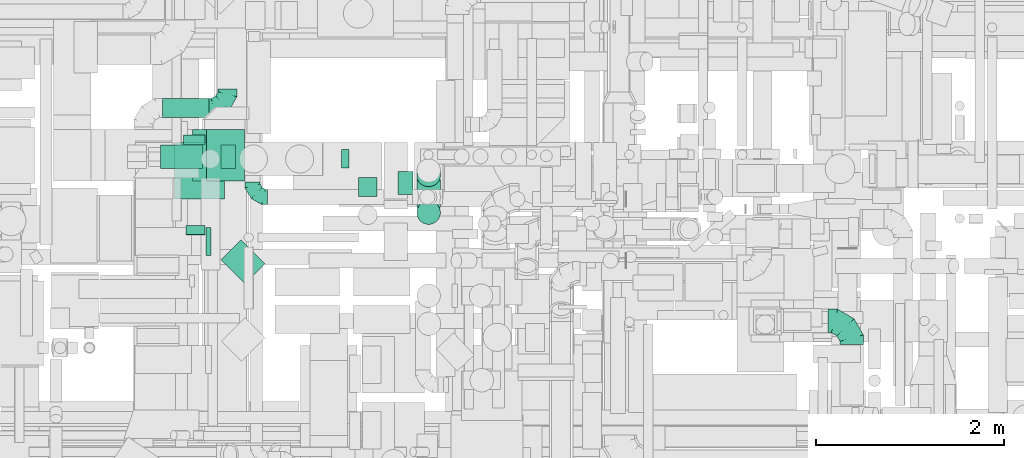
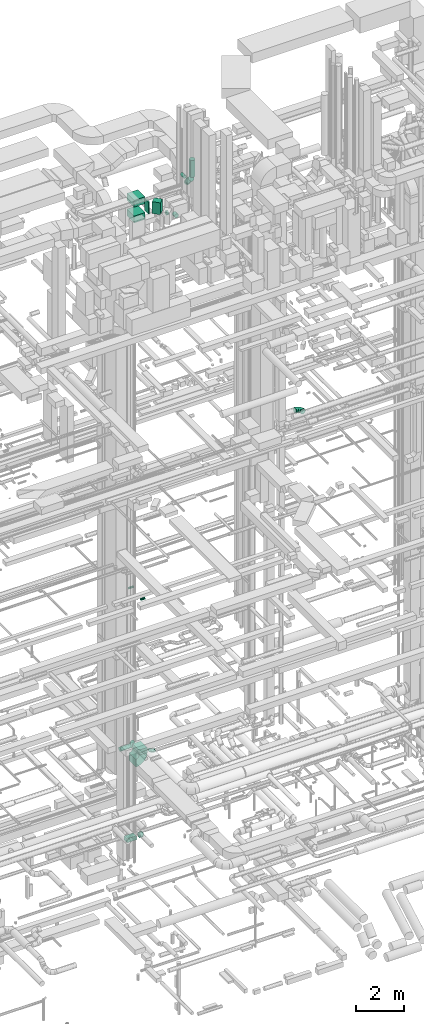
# One storey, part 188 of 337: 16 flow segments, 5 flow fittings.
"""IFC2X3 building model written with IfcOpenShell, lengths in millimetres."""

import ifcopenshell
import ifcopenshell.guid

model = None  # the IFC model being written
_history = None  # IfcOwnerHistory: only IFC2X3 demands one
_inside = {}  # id of a spatial element -> (the spatial element, [elements in it])
_under = {}  # id of a project, library or spatial element -> (it, [spatial elements below it])
_declared = {}  # id of a project -> (the project, [libraries it declares])
_typed = {}  # id of a type object -> (the type object, [elements of that type])
_made_of = {}  # id of a material, layer set ... -> (it, [elements and type objects made of it])


def new_model(schema):
    """Start an empty IFC model of exactly this schema.

    Asked for "IFC4X3", IfcOpenShell would pick the latest addendum, in which some entities
    have other attributes; the version numbers below select the first issue.
    IFC2X3 requires an IfcOwnerHistory on every rooted entity: one is made here for all.
    """
    global model, _history
    if schema == "IFC4X3":
        model = ifcopenshell.file(schema_version=(4, 3, 0, 0))
    else:
        model = ifcopenshell.file(schema=schema)
    _inside.clear()
    _under.clear()
    _declared.clear()
    _typed.clear()
    _made_of.clear()
    _history = None
    if model.schema == "IFC2X3":
        org = make("IfcOrganization", Name="unknown")
        user = make(
            "IfcPersonAndOrganization",
            ThePerson=make("IfcPerson", FamilyName="unknown"),
            TheOrganization=org,
        )
        app = make(
            "IfcApplication",
            ApplicationDeveloper=org,
            Version="unknown",
            ApplicationFullName="unknown",
            ApplicationIdentifier="unknown",
        )
        _history = make(
            "IfcOwnerHistory",
            OwningUser=user,
            OwningApplication=app,
            ChangeAction="ADDED",
            CreationDate=0,
        )
    return model


def make(cls, **values):
    """One entity of the class cls with the attributes given. An attribute that is None is left unset."""
    return model.create_entity(
        cls, **{name: value for name, value in values.items() if value is not None}
    )


def entity(cls, *values):
    """Any entity or typed value of the class cls, its attributes in the order of the schema. None: left unset."""
    e = model.create_entity(cls)
    for i, value in enumerate(values):
        if value is not None:
            e[i] = value
    return e


def rooted(cls, **values):
    """An entity with a GlobalId (a new one), such as an element, a storey or a relation."""
    return make(cls, GlobalId=ifcopenshell.guid.new(), OwnerHistory=_history, **values)


def si_unit(unit_type, name, prefix=None):
    """IfcSIUnit, for example si_unit("LENGTHUNIT", "METRE", prefix="MILLI")."""
    return make("IfcSIUnit", UnitType=unit_type, Prefix=prefix, Name=name)


def converted_unit(unit_type, name, factor, base, dimensions=None, offset=None):
    """IfcConversionBasedUnit, such as the inch: factor (a typed value) times the base unit."""
    return make(
        "IfcConversionBasedUnit"
        if offset is None
        else "IfcConversionBasedUnitWithOffset",
        ConversionOffset=offset,
        Dimensions=None
        if dimensions is None
        else entity("IfcDimensionalExponents", *dimensions),
        UnitType=unit_type,
        Name=name,
        ConversionFactor=make(
            "IfcMeasureWithUnit", ValueComponent=factor, UnitComponent=base
        ),
    )


def derived_unit(unit_type, elements):
    """IfcDerivedUnit: a product of units, each with its exponent."""
    return make(
        "IfcDerivedUnit",
        Elements=[
            make("IfcDerivedUnitElement", Unit=unit, Exponent=power)
            for unit, power in elements
        ],
        UnitType=unit_type,
    )


def assignment(units):
    """IfcUnitAssignment: the units of a project."""
    return None if units is None else make("IfcUnitAssignment", Units=units)


def point(xyz):
    """IfcCartesianPoint."""
    return None if xyz is None else make("IfcCartesianPoint", Coordinates=xyz)


def direction(xyz):
    """IfcDirection."""
    return None if xyz is None else make("IfcDirection", DirectionRatios=xyz)


def frame(location, z_axis=None, x_axis=None):
    """IfcAxis2Placement3D, a coordinate frame: its origin and axes. An axis left out is left unset."""
    return make(
        "IfcAxis2Placement3D",
        Location=point(location),
        Axis=direction(z_axis),
        RefDirection=direction(x_axis),
    )


def frame_2d(location, x_axis=None):
    """IfcAxis2Placement2D, a coordinate frame in the plane: its origin and x axis."""
    return make(
        "IfcAxis2Placement2D", Location=point(location), RefDirection=direction(x_axis)
    )


def origin():
    """The frame at (0, 0, 0) with its axes left unset."""
    return frame((0.0, 0.0, 0.0))


def origin_2d_with_axis():
    """The frame at (0, 0) in the plane with the x axis (1, 0) written out."""
    return frame_2d((0.0, 0.0), x_axis=(1.0, 0.0))


def place(relative_to, where):
    """IfcLocalPlacement: puts the frame where relative to a parent placement (None: the world)."""
    return make(
        "IfcLocalPlacement", PlacementRelTo=relative_to, RelativePlacement=where
    )


def context(
    kind, dimensions, precision=None, world=None, true_north=None, identifier=None
):
    """IfcGeometricRepresentationContext, for example the 3D "Model" context."""
    return make(
        "IfcGeometricRepresentationContext",
        ContextIdentifier=identifier,
        ContextType=kind,
        CoordinateSpaceDimension=dimensions,
        Precision=precision,
        WorldCoordinateSystem=world,
        TrueNorth=true_north,
    )


def subcontext(parent, identifier, kind, view, scale=None):
    """IfcGeometricRepresentationSubContext, for example "Body" below "Model"."""
    return make(
        "IfcGeometricRepresentationSubContext",
        ContextIdentifier=identifier,
        ContextType=kind,
        ParentContext=parent,
        TargetScale=scale,
        TargetView=view,
    )


def project(units=None, contexts=None):
    """IfcProject with its units and contexts."""
    return rooted(
        "IfcProject",
        Name="project",
        RepresentationContexts=contexts,
        UnitsInContext=assignment(units),
    )


def spatial(cls, under=None, at=None, **own):
    """A site, building, storey or space (cls), placed at a placement, below another one or the project."""
    s = rooted(cls, ObjectPlacement=at, **own)
    if under is not None:
        _under.setdefault(under.id(), (under, []))[1].append(s)
    return s


def polyline(points):
    """IfcPolyline through the points."""
    return make("IfcPolyline", Points=[point(p) for p in points])


def circle_curve(where, radius):
    """IfcCircle in the frame where."""
    return make("IfcCircle", Position=where, Radius=radius)


def parameter(value):
    """IfcParameterValue: where a trimmed curve begins or ends, as a parameter of its basis curve."""
    return model.create_entity("IfcParameterValue", value)


def trimmed(basis, trim1, trim2, sense, master):
    """IfcTrimmedCurve: the piece of a basis curve between two trims."""
    return make(
        "IfcTrimmedCurve",
        BasisCurve=basis,
        Trim1=trim1,
        Trim2=trim2,
        SenseAgreement=sense,
        MasterRepresentation=master,
    )


def segment(curve, same_sense, transition):
    """IfcCompositeCurveSegment."""
    return make(
        "IfcCompositeCurveSegment",
        Transition=transition,
        SameSense=same_sense,
        ParentCurve=curve,
    )


def composite_curve(segments, self_intersect=None):
    """IfcCompositeCurve: segments joined end to end."""
    return make("IfcCompositeCurve", Segments=segments, SelfIntersect=self_intersect)


def profile(cls, at=None, kind="AREA", **sizes):
    """A parametric profile (cls). Its sizes go by their IFC names, for example OverallWidth=200.0."""
    return make(cls, ProfileType=kind, Position=at, **sizes)


def rectangle(**sizes):
    """IfcRectangleProfileDef."""
    return profile("IfcRectangleProfileDef", **sizes)


def circle(**sizes):
    """IfcCircleProfileDef."""
    return profile("IfcCircleProfileDef", **sizes)


def outline(outer, holes=None, kind="AREA"):
    """IfcArbitraryClosedProfileDef: a profile drawn as a closed curve; with holes, ...WithVoids."""
    if holes is None:
        return make("IfcArbitraryClosedProfileDef", ProfileType=kind, OuterCurve=outer)
    return make(
        "IfcArbitraryProfileDefWithVoids",
        ProfileType=kind,
        OuterCurve=outer,
        InnerCurves=holes,
    )


def extrude(swept, where, along, depth):
    """IfcExtrudedAreaSolid: the profile swept, set in the frame where, extruded along a direction by depth."""
    return make(
        "IfcExtrudedAreaSolid",
        SweptArea=swept,
        Position=where,
        ExtrudedDirection=direction(along),
        Depth=depth,
    )


def faces_of(points, faces, orient=None, outer=None):
    """IfcFace entities. A face is a list of loops; a loop is a list of indices into points, from 0.

    orient and outer hold one flag for each loop. By default every Orientation is true, the
    first loop of a face is its IfcFaceOuterBound and the others are IfcFaceBound.
    """
    made = []
    for i, loops in enumerate(faces):
        bounds = []
        for j, loop in enumerate(loops):
            is_outer = j == 0 if outer is None else outer[i][j]
            bounds.append(
                make(
                    "IfcFaceOuterBound" if is_outer else "IfcFaceBound",
                    Bound=make("IfcPolyLoop", Polygon=[points[k] for k in loop]),
                    Orientation=True if orient is None else orient[i][j],
                )
            )
        made.append(make("IfcFace", Bounds=bounds))
    return made


def faceted_brep(points, faces, orient=None, outer=None, voids=None):
    """IfcFacetedBrep: a solid bounded by flat faces; with voids (closed shells), ...WithVoids."""
    shared = [point(p) for p in points]
    hull = make("IfcClosedShell", CfsFaces=faces_of(shared, faces, orient, outer))
    if voids is None:
        return make("IfcFacetedBrep", Outer=hull)
    return make(
        "IfcFacetedBrepWithVoids",
        Outer=hull,
        Voids=[
            make(cls, CfsFaces=faces_of(shared, fs, o, b)) for cls, fs, o, b in voids
        ],
    )


def shape(context_of_items, identifier, shape_type, items):
    """IfcShapeRepresentation: the items that make up one representation, for example the "Body"."""
    return make(
        "IfcShapeRepresentation",
        ContextOfItems=context_of_items,
        RepresentationIdentifier=identifier,
        RepresentationType=shape_type,
        Items=items,
    )


def source(mapping_origin, context_of_items, identifier, shape_type, items):
    """IfcRepresentationMap: a shape defined once, which mapped items show again and again."""
    return make(
        "IfcRepresentationMap",
        MappingOrigin=mapping_origin,
        MappedRepresentation=shape(context_of_items, identifier, shape_type, items),
    )


def transform(
    local_origin,
    x_axis=None,
    y_axis=None,
    z_axis=None,
    scale=None,
    scale2=None,
    scale3=None,
    uniform=True,
):
    """IfcCartesianTransformationOperator3D, or its non-uniform kind. x_axis, y_axis, z_axis: its Axis1, 2, 3."""
    if uniform:
        return make(
            "IfcCartesianTransformationOperator3D",
            Axis1=direction(x_axis),
            Axis2=direction(y_axis),
            LocalOrigin=point(local_origin),
            Scale=scale,
            Axis3=direction(z_axis),
        )
    return make(
        "IfcCartesianTransformationOperator3DnonUniform",
        Axis1=direction(x_axis),
        Axis2=direction(y_axis),
        LocalOrigin=point(local_origin),
        Scale=scale,
        Axis3=direction(z_axis),
        Scale2=scale2,
        Scale3=scale3,
    )


def mapped(mapping_source, mapping_target):
    """IfcMappedItem: shows the shape of a source again, moved by a transform."""
    return make(
        "IfcMappedItem", MappingSource=mapping_source, MappingTarget=mapping_target
    )


def material(Name=None, Category=None):
    """IfcMaterial."""
    return make("IfcMaterial", Name=Name, Category=Category)


def made_of(thing, what):
    """Note that an element or type object is made of a material, layer set ...; save() writes the relation."""
    if what is not None:
        _made_of.setdefault(what.id(), (what, []))[1].append(thing)
    return thing


def type_object(cls, material=None, **own):
    """A type object (cls), such as IfcWallType, which elements share."""
    return made_of(rooted(cls, **own), material)


def type_shapes(of_type, sources):
    """Give a type object the sources (RepresentationMaps) that its elements show as mapped items."""
    of_type.RepresentationMaps = sources


def element(
    cls,
    number,
    at=None,
    inside=None,
    cuts=None,
    type_object=None,
    material=None,
    context=None,
    identifier="Body",
    shape_type=None,
    held_by="IfcProductDefinitionShape",
    body=None,
    shapes=None,
    **own,
):
    """One element of the class cls, such as IfcWall. Its Tag is "e" and its number.

    at: its placement. inside: the storey or other place that contains it. cuts: it is an
    opening in that element (IfcRelVoidsElement). A single representation is given by context,
    identifier, shape_type and body (its items); several are given by shapes. held_by: the class
    of the entity that holds the representations. save() writes the other relations.
    """
    e = rooted(cls, Tag="e%d" % number, ObjectPlacement=at, **own)
    if body is not None:
        shapes = [shape(context, identifier, shape_type, body)]
    if shapes is not None:
        e.Representation = make(held_by, Representations=shapes)
    if inside is not None:
        _inside.setdefault(inside.id(), (inside, []))[1].append(e)
    if cuts is not None:
        rooted(
            "IfcRelVoidsElement", RelatingBuildingElement=cuts, RelatedOpeningElement=e
        )
    if type_object is not None:
        _typed.setdefault(type_object.id(), (type_object, []))[1].append(e)
    return made_of(e, material)


def aggregate(whole, parts):
    """IfcRelAggregates: a whole, such as a stair, and the parts it consists of."""
    return rooted("IfcRelAggregates", RelatingObject=whole, RelatedObjects=parts)


def save(model, path):
    """Write the relations noted so far, then the file.

    IfcRelAggregates (storeys below a building ...), IfcRelContainedInSpatialStructure (elements
    in a storey), IfcRelDefinesByType, IfcRelAssociatesMaterial and IfcRelDeclares: one each for
    every whole, place, type object, material and project.
    """
    for whole, parts in _under.values():
        aggregate(whole, parts)
    for where, things in _inside.values():
        rooted(
            "IfcRelContainedInSpatialStructure",
            RelatedElements=things,
            RelatingStructure=where,
        )
    for kind, things in _typed.values():
        rooted("IfcRelDefinesByType", RelatedObjects=things, RelatingType=kind)
    for what, things in _made_of.values():
        rooted("IfcRelAssociatesMaterial", RelatedObjects=things, RelatingMaterial=what)
    for by, libraries in _declared.values():
        rooted("IfcRelDeclares", RelatingContext=by, RelatedDefinitions=libraries)
    model.write(path)


model = new_model("IFC2X3")

# Units and contexts
model_context = context("Model", 3, precision=0.01, world=origin(), true_north=direction((6.12303176911189e-17, 1.0)))
body_context = subcontext(model_context, "Body", "Model", "MODEL_VIEW")
ifc_project = project(units=[si_unit("LENGTHUNIT", "METRE", prefix="MILLI"), si_unit("AREAUNIT", "SQUARE_METRE"), si_unit("VOLUMEUNIT", "CUBIC_METRE"), converted_unit("PLANEANGLEUNIT", "DEGREE", entity("IfcRatioMeasure", 0.0174532925199433), si_unit("PLANEANGLEUNIT", "RADIAN"), dimensions=[0, 0, 0, 0, 0, 0, 0]), si_unit("MASSUNIT", "GRAM", prefix="KILO"), derived_unit("MASSDENSITYUNIT", [(si_unit("MASSUNIT", "GRAM", prefix="KILO"), 1), (si_unit("LENGTHUNIT", "METRE"), -3)]), derived_unit("MOMENTOFINERTIAUNIT", [(si_unit("LENGTHUNIT", "METRE"), 4)]), si_unit("TIMEUNIT", "SECOND"), si_unit("FREQUENCYUNIT", "HERTZ"), si_unit("THERMODYNAMICTEMPERATUREUNIT", "DEGREE_CELSIUS"), derived_unit("THERMALTRANSMITTANCEUNIT", [(si_unit("MASSUNIT", "GRAM", prefix="KILO"), 1), (si_unit("THERMODYNAMICTEMPERATUREUNIT", "KELVIN"), -1), (si_unit("TIMEUNIT", "SECOND"), -3)]), derived_unit("VOLUMETRICFLOWRATEUNIT", [(si_unit("LENGTHUNIT", "METRE"), 3), (si_unit("TIMEUNIT", "SECOND"), -1)]), derived_unit("MASSFLOWRATEUNIT", [(si_unit("MASSUNIT", "GRAM", prefix="KILO"), 1), (si_unit("TIMEUNIT", "SECOND"), -1)]), derived_unit("ROTATIONALFREQUENCYUNIT", [(si_unit("TIMEUNIT", "SECOND"), -1)]), si_unit("ELECTRICCURRENTUNIT", "AMPERE"), si_unit("ELECTRICVOLTAGEUNIT", "VOLT"), si_unit("POWERUNIT", "WATT"), si_unit("FORCEUNIT", "NEWTON", prefix="KILO"), si_unit("ILLUMINANCEUNIT", "LUX"), si_unit("LUMINOUSFLUXUNIT", "LUMEN"), si_unit("LUMINOUSINTENSITYUNIT", "CANDELA"), derived_unit("USERDEFINED", [(si_unit("MASSUNIT", "GRAM", prefix="KILO"), -1), (si_unit("LENGTHUNIT", "METRE"), -2), (si_unit("TIMEUNIT", "SECOND"), 3), (si_unit("LUMINOUSFLUXUNIT", "LUMEN"), 1)]), derived_unit("LINEARVELOCITYUNIT", [(si_unit("LENGTHUNIT", "METRE"), 1), (si_unit("TIMEUNIT", "SECOND"), -1)]), si_unit("PRESSUREUNIT", "PASCAL"), derived_unit("USERDEFINED", [(si_unit("LENGTHUNIT", "METRE"), -2), (si_unit("MASSUNIT", "GRAM", prefix="KILO"), 1), (si_unit("TIMEUNIT", "SECOND"), -2)]), derived_unit("LINEARFORCEUNIT", [(si_unit("MASSUNIT", "GRAM", prefix="KILO"), 1), (si_unit("LENGTHUNIT", "METRE"), 1), (si_unit("TIMEUNIT", "SECOND"), -2), (si_unit("LENGTHUNIT", "METRE"), -1)]), derived_unit("PLANARFORCEUNIT", [(si_unit("MASSUNIT", "GRAM", prefix="KILO"), 1), (si_unit("LENGTHUNIT", "METRE"), 1), (si_unit("TIMEUNIT", "SECOND"), -2), (si_unit("LENGTHUNIT", "METRE"), -2)])], contexts=[model_context])

# Site, building, storey
site_placement = place(None, origin())
site = spatial("IfcSite", under=ifc_project, at=site_placement, CompositionType="ELEMENT")
building_placement = place(site_placement, origin())
building = spatial("IfcBuilding", under=site, at=building_placement, CompositionType="ELEMENT")
storey_placement = place(building_placement, origin())
storey = spatial("IfcBuildingStorey", under=building, at=storey_placement, CompositionType="ELEMENT", Elevation=0.0)

# Flow segments
duct_segment_type_1 = type_object("IfcDuctSegmentType", PredefinedType="NOTDEFINED")
flow_segment_1_placement = place(storey_placement, frame((46164.19, 12895.83, -1200.0)))
element("IfcFlowSegment", 1, at=flow_segment_1_placement, inside=storey, type_object=duct_segment_type_1, context=body_context, shape_type="SweptSolid", body=[
    extrude(rectangle(XDim=443.906215000016, YDim=249.999999999999, at=origin_2d_with_axis()), frame((221.95, 125.0, 0.0)), (0.0, 0.0, 1.0), 200.0),
])
flow_segment_2_placement = place(storey_placement, frame((46806.89, 11671.41, 31100.0)))
element("IfcFlowSegment", 2, at=flow_segment_2_placement, inside=storey, type_object=duct_segment_type_1, context=body_context, shape_type="SweptSolid", body=[
    extrude(rectangle(XDim=360.997907958926, YDim=299.999999999999, at=origin_2d_with_axis()), frame((233.7, 233.7, 0.0), z_axis=(0.0, 0.0, 1.0), x_axis=(-0.707106781186521, 0.707106781186575, 0.0)), (0.0, 0.0, 1.0), 600.000000000002),
])
flow_segment_3_placement = place(storey_placement, frame((46645.05, 11970.6, 31100.0)))
element("IfcFlowSegment", 3, at=flow_segment_3_placement, inside=storey, type_object=duct_segment_type_1, context=body_context, shape_type="SweptSolid", body=[
    extrude(rectangle(XDim=55.7803012880717, YDim=299.999999999999, at=origin_2d_with_axis()), frame((27.89, 150.0, 0.0), z_axis=(0.0, 0.0, 1.0), x_axis=(-1.0, 0.0, 0.0)), (0.0, 0.0, 1.0), 600.000000000002),
])
for number, where in (
    (4, (46315.05, 12574.75, 30395.0)),
    (5, (46315.05, 12574.75, 31195.0)),
):
    element("IfcFlowSegment", number, at=place(storey_placement, frame(where)), inside=storey, type_object=duct_segment_type_1, context=body_context, shape_type="SweptSolid", body=[
        extrude(rectangle(XDim=529.434116799874, YDim=600.0, at=origin_2d_with_axis()), frame((264.72, 300.0, 0.0), z_axis=(0.0, 0.0, 1.0), x_axis=(-1.0, 0.0, 0.0)), (0.0, 0.0, 1.0), 349.999999999998),
    ])
flow_segment_4_placement = place(storey_placement, frame((46655.22, 12764.41, 3150.0)))
element("IfcFlowSegment", 6, at=flow_segment_4_placement, inside=storey, type_object=duct_segment_type_1, context=body_context, shape_type="SweptSolid", body=[
    extrude(rectangle(XDim=399.999999999996, YDim=550.000000000001, at=origin_2d_with_axis()), frame((200.0, 275.0, 0.0), z_axis=(0.0, 0.0, 1.0), x_axis=(-1.0, 0.0, 0.0)), (0.0, 0.0, 1.0), 104.992243663987),
])
duct_segment_type_2 = type_object("IfcDuctSegmentType", PredefinedType="NOTDEFINED")
flow_segment_5_placement = place(storey_placement, frame((46808.09, 12894.23, -1226.6)))
element("IfcFlowSegment", 7, at=flow_segment_5_placement, inside=storey, type_object=duct_segment_type_2, context=body_context, shape_type="SweptSolid", body=[
    extrude(circle(Radius=125.0, at=origin_2d_with_axis()), frame((0.0, 126.6, 126.6), z_axis=(1.0, 0.0, 0.0), x_axis=(0.0, 1.0, 0.0)), (0.0, 0.0, 1.0), 152.496840000005),
])
flow_segment_6_placement = place(storey_placement, frame((46435.67, 12188.95, 11398.4)))
element("IfcFlowSegment", 8, at=flow_segment_6_placement, inside=storey, type_object=duct_segment_type_2, context=body_context, shape_type="SweptSolid", body=[
    extrude(circle(Radius=50.0, at=origin_2d_with_axis()), frame((0.0, 51.6, 51.6), z_axis=(1.0, 0.0, 0.0), x_axis=(0.0, -1.0, 0.0)), (0.0, 0.0, 1.0), 199.999999999894),
])
flow_segment_7_placement = place(storey_placement, frame((46405.67, 13151.59, 11398.4)))
element("IfcFlowSegment", 9, at=flow_segment_7_placement, inside=storey, type_object=duct_segment_type_2, context=body_context, shape_type="SweptSolid", body=[
    extrude(circle(Radius=50.0, at=origin_2d_with_axis()), frame((0.0, 51.6, 51.6), z_axis=(1.0, 0.0, 0.0), x_axis=(0.0, -1.0, 0.0)), (0.0, 0.0, 1.0), 229.999999999896),
])
flow_segment_8_placement = place(storey_placement, frame((48089.82, 12898.0, 29923.4)))
element("IfcFlowSegment", 10, at=flow_segment_8_placement, inside=storey, type_object=duct_segment_type_2, context=body_context, shape_type="SweptSolid", body=[
    extrude(circle(Radius=100.0, at=origin_2d_with_axis()), frame((0.0, 101.6, 101.6), z_axis=(1.0, 0.0, 0.0), x_axis=(0.0, -1.0, 0.0)), (0.0, 0.0, 1.0), 80.2842077418905),
])
flow_segment_9_placement = place(storey_placement, frame((48268.51, 12600.0, 29923.4)))
element("IfcFlowSegment", 11, at=flow_segment_9_placement, inside=storey, type_object=duct_segment_type_2, context=body_context, shape_type="SweptSolid", body=[
    extrude(circle(Radius=100.0, at=origin_2d_with_axis()), frame((101.6, 0.0, 101.6), z_axis=(0.0, 1.0, 0.0), x_axis=(-1.0, 0.0, 0.0)), (0.0, 0.0, 1.0), 199.592425000005),
])
flow_segment_10_placement = place(storey_placement, frame((48890.99, 12702.42, 31295.81)))
element("IfcFlowSegment", 12, at=flow_segment_10_placement, inside=storey, type_object=duct_segment_type_2, context=body_context, shape_type="SweptSolid", body=[
    extrude(circle(Radius=125.0, at=origin_2d_with_axis()), frame((126.6, 148.9, 54.42), z_axis=(0.0, -0.422618261740703, 0.906307787036648), x_axis=(-1.0, 0.0, 0.0)), (0.0, 0.0, 1.0), 80.494589162154),
])
flow_segment_11_placement = place(storey_placement, frame((48890.99, 12410.15, 31404.32)))
element("IfcFlowSegment", 13, at=flow_segment_11_placement, inside=storey, type_object=duct_segment_type_2, context=body_context, shape_type="SweptSolid", body=[
    extrude(circle(Radius=125.0, at=origin_2d_with_axis()), frame((126.6, 89.98, 357.36), z_axis=(0.0, 0.707106781186548, -0.707106781186548), x_axis=(1.0, 0.0, 0.0)), (0.0, 0.0, 1.0), 378.123620747685),
])
flow_segment_12_placement = place(storey_placement, frame((48890.99, 12300.31, 31938.46)))
element("IfcFlowSegment", 14, at=flow_segment_12_placement, inside=storey, type_object=duct_segment_type_2, context=body_context, shape_type="SweptSolid", body=[
    extrude(circle(Radius=125.0, at=origin_2d_with_axis()), frame((126.6, 126.6, 0.0), z_axis=(0.0, 0.0, 1.0), x_axis=(-1.0, 0.0, 0.0)), (0.0, 0.0, 1.0), 856.446609406737),
])
flow_segment_13_placement = place(storey_placement, frame((48688.49, 12617.98, 31768.4)))
element("IfcFlowSegment", 15, at=flow_segment_13_placement, inside=storey, type_object=duct_segment_type_2, context=body_context, shape_type="SweptSolid", body=[
    extrude(circle(Radius=80.0, at=origin_2d_with_axis()), frame((81.6, 0.0, 81.6), z_axis=(0.0, 1.0, 0.0), x_axis=(1.0, 0.0, 0.0)), (0.0, 0.0, 1.0), 247.011860042148),
])
flow_segment_14_placement = place(storey_placement, frame((46182.19, 13439.47, 3048.4)))
element("IfcFlowSegment", 16, at=flow_segment_14_placement, inside=storey, type_object=duct_segment_type_2, context=body_context, shape_type="SweptSolid", body=[
    extrude(circle(Radius=100.0, at=origin_2d_with_axis()), frame((0.0, 101.6, 101.6), z_axis=(1.0, 0.0, 0.0), x_axis=(0.0, -1.0, 0.0)), (0.0, 0.0, 1.0), 495.000000000113),
])

# Flow fittings
ifc_material = material()
duct_fitting_type_1 = type_object("IfcDuctFittingType", PredefinedType="NOTDEFINED", material=ifc_material)
shared_shape_1 = source(origin(), body_context, "Body", "SweptSolid", [
    extrude(rectangle(XDim=550.0, YDim=148.018359359705, at=origin_2d_with_axis()), frame((-54.01, 0.0, -200.0), z_axis=(0.0, 0.0, 1.0), x_axis=(0.0, -1.0, 0.0)), (0.0, 0.0, 1.0), 400.0),
])
type_shapes(duct_fitting_type_1, [shared_shape_1])
flow_fitting_1_placement = place(storey_placement, frame((46855.22, 13039.41, 3274.99), z_axis=(-1.0, 0.0, 0.0), x_axis=(0.0, 0.0, -1.0)))
element("IfcFlowFitting", 17, at=flow_fitting_1_placement, inside=storey, type_object=duct_fitting_type_1, material=ifc_material, context=body_context, shape_type="MappedRepresentation", body=[
    mapped(shared_shape_1, transform((0.0, 0.0, 0.0), scale=1.0)),
])
duct_fitting_type_2 = type_object("IfcDuctFittingType", PredefinedType="NOTDEFINED", material=ifc_material)
shared_shape_2 = source(origin(), body_context, "Body", "Brep", [
    faceted_brep([(-160.0, 0.0, -80.0), (-160.0, -20.71, -77.27), (-160.0, -40.0, -69.28), (-160.0, -56.57, -56.57), (-160.0, -69.28, -40.0), (-160.0, -77.27, -20.71), (-160.0, -80.0, 0.0), (-160.0, -77.27, 20.71), (-160.0, -69.28, 40.0), (-160.0, -56.57, 56.57), (-160.0, -40.0, 69.28), (-160.0, -20.71, 77.27), (-160.0, 0.0, 80.0), (-160.0, 20.71, 77.27), (-160.0, 40.0, 69.28), (-160.0, 56.57, 56.57), (-160.0, 69.28, 40.0), (-160.0, 77.27, 20.71), (-160.0, 80.0, 0.0), (-160.0, 77.27, -20.71), (-160.0, 69.28, -40.0), (-160.0, 56.57, -56.57), (-160.0, 40.0, -69.28), (-160.0, 20.71, -77.27), (-122.68, 20.71, 77.27), (-127.85, 40.0, 69.28), (-117.13, 0.0, 80.0), (-132.29, 56.57, 56.57), (-137.83, 77.27, 20.71), (-138.56, 80.0, 0.0), (-135.69, 69.28, 40.0), (-135.69, 69.28, -40.0), (-132.29, 56.57, -56.57), (-137.83, 77.27, -20.71), (-122.68, 20.71, -77.27), (-117.13, 0.0, -80.0), (-127.85, 40.0, -69.28), (-111.58, -20.71, -77.27), (-106.41, -40.0, -69.28), (-101.97, -56.57, -56.57), (-98.56, -69.28, -40.0), (-96.42, -77.27, -20.71), (-95.69, -80.0, 0.0), (-96.42, -77.27, 20.71), (-98.56, -69.28, 40.0), (-101.97, -56.57, 56.57), (-106.41, -40.0, 69.28), (-111.58, -20.71, 77.27), (-58.03, 58.03, 77.27), (-72.15, 72.15, 69.28), (-42.87, 42.87, 80.0), (-84.28, 84.28, 56.57), (-93.59, 93.59, 40.0), (-99.44, 99.44, 20.71), (-101.44, 101.44, 0.0), (-99.44, 99.44, -20.71), (-93.59, 93.59, -40.0), (-84.28, 84.28, -56.57), (-58.03, 58.03, -77.27), (-42.87, 42.87, -80.0), (-72.15, 72.15, -69.28), (-27.71, 27.71, -77.27), (-13.59, 13.59, -69.28), (-1.46, 1.46, -56.57), (7.85, -7.85, -40.0), (13.7, -13.7, -20.71), (15.69, -15.69, 0.0), (13.7, -13.7, 20.71), (7.85, -7.85, 40.0), (-1.46, 1.46, 56.57), (-13.59, 13.59, 69.28), (-27.71, 27.71, 77.27), (-20.71, 122.68, 77.27), (-40.0, 127.85, 69.28), (0.0, 117.13, 80.0), (-56.57, 132.29, 56.57), (-69.28, 135.69, 40.0), (-77.27, 137.83, 20.71), (-80.0, 138.56, 0.0), (-77.27, 137.83, -20.71), (-69.28, 135.69, -40.0), (-56.57, 132.29, -56.57), (-20.71, 122.68, -77.27), (0.0, 117.13, -80.0), (-40.0, 127.85, -69.28), (20.71, 111.58, -77.27), (40.0, 106.41, -69.28), (56.57, 101.97, -56.57), (69.28, 98.56, -40.0), (77.27, 96.42, -20.71), (80.0, 95.69, 0.0), (77.27, 96.42, 20.71), (69.28, 98.56, 40.0), (56.57, 101.97, 56.57), (40.0, 106.41, 69.28), (20.71, 111.58, 77.27), (-20.71, 160.0, -77.27), (-40.0, 160.0, -69.28), (-56.57, 160.0, -56.57), (-69.28, 160.0, -40.0), (-77.27, 160.0, -20.71), (-80.0, 160.0, 0.0), (-77.27, 160.0, 20.71), (-69.28, 160.0, 40.0), (-56.57, 160.0, 56.57), (-40.0, 160.0, 69.28), (-20.71, 160.0, 77.27), (0.0, 160.0, 80.0), (20.71, 160.0, 77.27), (40.0, 160.0, 69.28), (56.57, 160.0, 56.57), (69.28, 160.0, 40.0), (77.27, 160.0, 20.71), (80.0, 160.0, 0.0), (77.27, 160.0, -20.71), (69.28, 160.0, -40.0), (56.57, 160.0, -56.57), (40.0, 160.0, -69.28), (20.71, 160.0, -77.27), (0.0, 160.0, -80.0)], [[[0, 1, 2, 3, 4, 5, 6, 7, 8, 9, 10, 11, 12, 13, 14, 15, 16, 17, 18, 19, 20, 21, 22, 23]], [[24, 25, 14, 13]], [[26, 24, 13, 12]], [[14, 25, 27, 15]], [[28, 29, 18, 17]], [[30, 28, 17, 16]], [[15, 27, 30, 16]], [[20, 31, 32, 21]], [[33, 31, 20, 19]], [[18, 29, 33, 19]], [[34, 35, 0, 23]], [[36, 34, 23, 22]], [[32, 36, 22, 21]], [[1, 0, 35, 37]], [[2, 1, 37, 38]], [[3, 2, 38, 39]], [[5, 4, 40, 41]], [[6, 5, 41, 42]], [[39, 40, 4, 3]], [[6, 42, 43, 7]], [[7, 43, 44, 8]], [[8, 44, 45, 9]], [[9, 45, 46, 10]], [[10, 46, 47, 11]], [[26, 12, 11, 47]], [[48, 49, 25, 24]], [[50, 48, 24, 26]], [[27, 25, 49, 51]], [[52, 53, 28, 30]], [[51, 52, 30, 27]], [[29, 28, 53, 54]], [[55, 56, 31, 33]], [[54, 55, 33, 29]], [[32, 31, 56, 57]], [[58, 59, 35, 34]], [[60, 58, 34, 36]], [[57, 60, 36, 32]], [[37, 35, 59, 61]], [[38, 37, 61, 62]], [[39, 38, 62, 63]], [[41, 40, 64, 65]], [[42, 41, 65, 66]], [[63, 64, 40, 39]], [[43, 42, 66, 67]], [[44, 43, 67, 68]], [[68, 69, 45, 44]], [[46, 45, 69, 70]], [[47, 46, 70, 71]], [[26, 47, 71, 50]], [[72, 73, 49, 48]], [[74, 72, 48, 50]], [[51, 49, 73, 75]], [[76, 77, 53, 52]], [[75, 76, 52, 51]], [[54, 53, 77, 78]], [[79, 80, 56, 55]], [[78, 79, 55, 54]], [[57, 56, 80, 81]], [[82, 83, 59, 58]], [[84, 82, 58, 60]], [[81, 84, 60, 57]], [[61, 59, 83, 85]], [[62, 61, 85, 86]], [[63, 62, 86, 87]], [[65, 64, 88, 89]], [[66, 65, 89, 90]], [[87, 88, 64, 63]], [[67, 66, 90, 91]], [[68, 67, 91, 92]], [[92, 93, 69, 68]], [[70, 69, 93, 94]], [[71, 70, 94, 95]], [[50, 71, 95, 74]], [[96, 97, 98, 99, 100, 101, 102, 103, 104, 105, 106, 107, 108, 109, 110, 111, 112, 113, 114, 115, 116, 117, 118, 119]], [[72, 74, 107, 106]], [[73, 72, 106, 105]], [[75, 73, 105, 104]], [[77, 76, 103, 102]], [[78, 77, 102, 101]], [[75, 104, 103, 76]], [[78, 101, 100, 79]], [[79, 100, 99, 80]], [[80, 99, 98, 81]], [[84, 97, 96, 82]], [[82, 96, 119, 83]], [[84, 81, 98, 97]], [[118, 117, 86, 85]], [[119, 118, 85, 83]], [[116, 87, 86, 117]], [[88, 115, 114, 89]], [[89, 114, 113, 90]], [[115, 88, 87, 116]], [[112, 111, 92, 91]], [[113, 112, 91, 90]], [[111, 110, 93, 92]], [[95, 94, 109, 108]], [[74, 95, 108, 107]], [[110, 109, 94, 93]]]),
])
type_shapes(duct_fitting_type_2, [shared_shape_2])
flow_fitting_2_placement = place(storey_placement, frame((47143.34, 12593.92, 3280.0), z_axis=(0.0, 0.0, 1.0), x_axis=(0.0, -1.0, 0.0)))
element("IfcFlowFitting", 18, at=flow_fitting_2_placement, inside=storey, type_object=duct_fitting_type_2, material=ifc_material, context=body_context, shape_type="MappedRepresentation", body=[
    mapped(shared_shape_2, transform((0.0, 0.0, 0.0), scale=1.0)),
])
duct_fitting_type_3 = type_object("IfcDuctFittingType", PredefinedType="NOTDEFINED", material=ifc_material)
shared_shape_3 = source(origin(), body_context, "Body", "Brep", [
    faceted_brep([(-250.0, 0.0, -125.0), (-250.0, -32.35, -120.74), (-250.0, -62.5, -108.25), (-250.0, -88.39, -88.39), (-250.0, -108.25, -62.5), (-250.0, -120.74, -32.35), (-250.0, -125.0, 0.0), (-250.0, -120.74, 32.35), (-250.0, -108.25, 62.5), (-250.0, -88.39, 88.39), (-250.0, -62.5, 108.25), (-250.0, -32.35, 120.74), (-250.0, 0.0, 125.0), (-250.0, 32.35, 120.74), (-250.0, 62.5, 108.25), (-250.0, 88.39, 88.39), (-250.0, 108.25, 62.5), (-250.0, 120.74, 32.35), (-250.0, 125.0, 0.0), (-250.0, 120.74, -32.35), (-250.0, 108.25, -62.5), (-250.0, 88.39, -88.39), (-250.0, 62.5, -108.25), (-250.0, 32.35, -120.74), (-191.68, 32.35, 120.74), (-199.76, 62.5, 108.25), (-183.01, 0.0, 125.0), (-206.7, 88.39, 88.39), (-215.37, 120.74, 32.35), (-216.51, 125.0, 0.0), (-212.02, 108.25, 62.5), (-212.02, 108.25, -62.5), (-206.7, 88.39, -88.39), (-215.37, 120.74, -32.35), (-191.68, 32.35, -120.74), (-183.01, 0.0, -125.0), (-199.76, 62.5, -108.25), (-174.34, -32.35, -120.74), (-166.27, -62.5, -108.25), (-159.33, -88.39, -88.39), (-154.01, -108.25, -62.5), (-150.66, -120.74, -32.35), (-149.52, -125.0, 0.0), (-150.66, -120.74, 32.35), (-154.01, -108.25, 62.5), (-159.33, -88.39, 88.39), (-166.27, -62.5, 108.25), (-174.34, -32.35, 120.74), (-90.67, 90.67, 120.74), (-112.74, 112.74, 108.25), (-66.99, 66.99, 125.0), (-131.69, 131.69, 88.39), (-146.23, 146.23, 62.5), (-155.38, 155.38, 32.35), (-158.49, 158.49, 0.0), (-155.38, 155.38, -32.35), (-146.23, 146.23, -62.5), (-131.69, 131.69, -88.39), (-90.67, 90.67, -120.74), (-66.99, 66.99, -125.0), (-112.74, 112.74, -108.25), (-43.3, 43.3, -120.74), (-21.23, 21.23, -108.25), (-2.28, 2.28, -88.39), (12.26, -12.26, -62.5), (21.4, -21.4, -32.35), (24.52, -24.52, 0.0), (21.4, -21.4, 32.35), (12.26, -12.26, 62.5), (-2.28, 2.28, 88.39), (-21.23, 21.23, 108.25), (-43.3, 43.3, 120.74), (-32.35, 191.68, 120.74), (-62.5, 199.76, 108.25), (0.0, 183.01, 125.0), (-88.39, 206.7, 88.39), (-108.25, 212.02, 62.5), (-120.74, 215.37, 32.35), (-125.0, 216.51, 0.0), (-120.74, 215.37, -32.35), (-108.25, 212.02, -62.5), (-88.39, 206.7, -88.39), (-32.35, 191.68, -120.74), (0.0, 183.01, -125.0), (-62.5, 199.76, -108.25), (32.35, 174.34, -120.74), (62.5, 166.27, -108.25), (88.39, 159.33, -88.39), (108.25, 154.01, -62.5), (120.74, 150.66, -32.35), (125.0, 149.52, 0.0), (120.74, 150.66, 32.35), (108.25, 154.01, 62.5), (88.39, 159.33, 88.39), (62.5, 166.27, 108.25), (32.35, 174.34, 120.74), (-32.35, 250.0, -120.74), (-62.5, 250.0, -108.25), (-88.39, 250.0, -88.39), (-108.25, 250.0, -62.5), (-120.74, 250.0, -32.35), (-125.0, 250.0, 0.0), (-120.74, 250.0, 32.35), (-108.25, 250.0, 62.5), (-88.39, 250.0, 88.39), (-62.5, 250.0, 108.25), (-32.35, 250.0, 120.74), (0.0, 250.0, 125.0), (32.35, 250.0, 120.74), (62.5, 250.0, 108.25), (88.39, 250.0, 88.39), (108.25, 250.0, 62.5), (120.74, 250.0, 32.35), (125.0, 250.0, 0.0), (120.74, 250.0, -32.35), (108.25, 250.0, -62.5), (88.39, 250.0, -88.39), (62.5, 250.0, -108.25), (32.35, 250.0, -120.74), (0.0, 250.0, -125.0)], [[[0, 1, 2, 3, 4, 5, 6, 7, 8, 9, 10, 11, 12, 13, 14, 15, 16, 17, 18, 19, 20, 21, 22, 23]], [[24, 25, 14, 13]], [[26, 24, 13, 12]], [[14, 25, 27, 15]], [[28, 29, 18, 17]], [[30, 28, 17, 16]], [[15, 27, 30, 16]], [[20, 31, 32, 21]], [[33, 31, 20, 19]], [[18, 29, 33, 19]], [[34, 35, 0, 23]], [[36, 34, 23, 22]], [[21, 32, 36, 22]], [[1, 0, 35, 37]], [[2, 1, 37, 38]], [[38, 39, 3, 2]], [[5, 4, 40, 41]], [[6, 5, 41, 42]], [[39, 40, 4, 3]], [[6, 42, 43, 7]], [[7, 43, 44, 8]], [[8, 44, 45, 9]], [[9, 45, 46, 10]], [[10, 46, 47, 11]], [[26, 12, 11, 47]], [[48, 49, 25, 24]], [[50, 48, 24, 26]], [[27, 25, 49, 51]], [[52, 53, 28, 30]], [[51, 52, 30, 27]], [[29, 28, 53, 54]], [[55, 56, 31, 33]], [[54, 55, 33, 29]], [[32, 31, 56, 57]], [[58, 59, 35, 34]], [[60, 58, 34, 36]], [[57, 60, 36, 32]], [[37, 35, 59, 61]], [[38, 37, 61, 62]], [[39, 38, 62, 63]], [[41, 40, 64, 65]], [[42, 41, 65, 66]], [[63, 64, 40, 39]], [[43, 42, 66, 67]], [[44, 43, 67, 68]], [[68, 69, 45, 44]], [[46, 45, 69, 70]], [[47, 46, 70, 71]], [[26, 47, 71, 50]], [[72, 73, 49, 48]], [[74, 72, 48, 50]], [[51, 49, 73, 75]], [[76, 77, 53, 52]], [[75, 76, 52, 51]], [[54, 53, 77, 78]], [[79, 80, 56, 55]], [[78, 79, 55, 54]], [[57, 56, 80, 81]], [[82, 83, 59, 58]], [[84, 82, 58, 60]], [[81, 84, 60, 57]], [[61, 59, 83, 85]], [[62, 61, 85, 86]], [[63, 62, 86, 87]], [[65, 64, 88, 89]], [[66, 65, 89, 90]], [[87, 88, 64, 63]], [[67, 66, 90, 91]], [[68, 67, 91, 92]], [[92, 93, 69, 68]], [[70, 69, 93, 94]], [[71, 70, 94, 95]], [[50, 71, 95, 74]], [[96, 97, 98, 99, 100, 101, 102, 103, 104, 105, 106, 107, 108, 109, 110, 111, 112, 113, 114, 115, 116, 117, 118, 119]], [[72, 74, 107, 106]], [[73, 72, 106, 105]], [[75, 73, 105, 104]], [[77, 76, 103, 102]], [[78, 77, 102, 101]], [[75, 104, 103, 76]], [[78, 101, 100, 79]], [[79, 100, 99, 80]], [[80, 99, 98, 81]], [[84, 97, 96, 82]], [[82, 96, 119, 83]], [[84, 81, 98, 97]], [[83, 119, 118, 85]], [[85, 118, 117, 86]], [[116, 87, 86, 117]], [[88, 115, 114, 89]], [[89, 114, 113, 90]], [[115, 88, 87, 116]], [[91, 90, 113, 112]], [[92, 91, 112, 111]], [[111, 110, 93, 92]], [[95, 94, 109, 108]], [[74, 95, 108, 107]], [[110, 109, 94, 93]]]),
])
type_shapes(duct_fitting_type_3, [shared_shape_3])
flow_fitting_3_placement = place(storey_placement, frame((53519.89, 11274.6, 19250.0), z_axis=(0.0, 0.0, 1.0), x_axis=(0.0, 1.0, 0.0)))
element("IfcFlowFitting", 19, at=flow_fitting_3_placement, inside=storey, type_object=duct_fitting_type_3, material=ifc_material, context=body_context, shape_type="MappedRepresentation", body=[
    mapped(shared_shape_3, transform((0.0, 0.0, 0.0), scale=1.0)),
])
duct_fitting_type_4 = type_object("IfcDuctFittingType", PredefinedType="NOTDEFINED", material=ifc_material)
shared_shape_4 = source(origin(), body_context, "Body", "Brep", [
    faceted_brep([(-200.0, 0.0, -100.0), (-200.0, -25.88, -96.59), (-200.0, -50.0, -86.6), (-200.0, -70.71, -70.71), (-200.0, -86.6, -50.0), (-200.0, -96.59, -25.88), (-200.0, -100.0, 0.0), (-200.0, -96.59, 25.88), (-200.0, -86.6, 50.0), (-200.0, -70.71, 70.71), (-200.0, -50.0, 86.6), (-200.0, -25.88, 96.59), (-200.0, 0.0, 100.0), (-200.0, 25.88, 96.59), (-200.0, 50.0, 86.6), (-200.0, 70.71, 70.71), (-200.0, 86.6, 50.0), (-200.0, 96.59, 25.88), (-200.0, 100.0, 0.0), (-200.0, 96.59, -25.88), (-200.0, 86.6, -50.0), (-200.0, 70.71, -70.71), (-200.0, 50.0, -86.6), (-200.0, 25.88, -96.59), (-153.35, 25.88, 96.59), (-159.81, 50.0, 86.6), (-146.41, 0.0, 100.0), (-165.36, 70.71, 70.71), (-172.29, 96.59, 25.88), (-173.21, 100.0, 0.0), (-169.62, 86.6, 50.0), (-169.62, 86.6, -50.0), (-165.36, 70.71, -70.71), (-172.29, 96.59, -25.88), (-153.35, 25.88, -96.59), (-146.41, 0.0, -100.0), (-159.81, 50.0, -86.6), (-139.48, -25.88, -96.59), (-133.01, -50.0, -86.6), (-127.46, -70.71, -70.71), (-123.21, -86.6, -50.0), (-120.53, -96.59, -25.88), (-119.62, -100.0, 0.0), (-120.53, -96.59, 25.88), (-123.21, -86.6, 50.0), (-127.46, -70.71, 70.71), (-133.01, -50.0, 86.6), (-139.48, -25.88, 96.59), (-72.54, 72.54, 96.59), (-90.19, 90.19, 86.6), (-53.59, 53.59, 100.0), (-105.35, 105.35, 70.71), (-116.99, 116.99, 50.0), (-124.3, 124.3, 25.88), (-126.79, 126.79, 0.0), (-124.3, 124.3, -25.88), (-116.99, 116.99, -50.0), (-105.35, 105.35, -70.71), (-72.54, 72.54, -96.59), (-53.59, 53.59, -100.0), (-90.19, 90.19, -86.6), (-34.64, 34.64, -96.59), (-16.99, 16.99, -86.6), (-1.83, 1.83, -70.71), (9.81, -9.81, -50.0), (17.12, -17.12, -25.88), (19.62, -19.62, 0.0), (17.12, -17.12, 25.88), (9.81, -9.81, 50.0), (-1.83, 1.83, 70.71), (-16.99, 16.99, 86.6), (-34.64, 34.64, 96.59), (-25.88, 153.35, 96.59), (-50.0, 159.81, 86.6), (0.0, 146.41, 100.0), (-70.71, 165.36, 70.71), (-86.6, 169.62, 50.0), (-96.59, 172.29, 25.88), (-100.0, 173.21, 0.0), (-96.59, 172.29, -25.88), (-86.6, 169.62, -50.0), (-70.71, 165.36, -70.71), (-25.88, 153.35, -96.59), (0.0, 146.41, -100.0), (-50.0, 159.81, -86.6), (25.88, 139.48, -96.59), (50.0, 133.01, -86.6), (70.71, 127.46, -70.71), (86.6, 123.21, -50.0), (96.59, 120.53, -25.88), (100.0, 119.62, 0.0), (96.59, 120.53, 25.88), (86.6, 123.21, 50.0), (70.71, 127.46, 70.71), (50.0, 133.01, 86.6), (25.88, 139.48, 96.59), (-25.88, 200.0, -96.59), (-50.0, 200.0, -86.6), (-70.71, 200.0, -70.71), (-86.6, 200.0, -50.0), (-96.59, 200.0, -25.88), (-100.0, 200.0, 0.0), (-96.59, 200.0, 25.88), (-86.6, 200.0, 50.0), (-70.71, 200.0, 70.71), (-50.0, 200.0, 86.6), (-25.88, 200.0, 96.59), (0.0, 200.0, 100.0), (25.88, 200.0, 96.59), (50.0, 200.0, 86.6), (70.71, 200.0, 70.71), (86.6, 200.0, 50.0), (96.59, 200.0, 25.88), (100.0, 200.0, 0.0), (96.59, 200.0, -25.88), (86.6, 200.0, -50.0), (70.71, 200.0, -70.71), (50.0, 200.0, -86.6), (25.88, 200.0, -96.59), (0.0, 200.0, -100.0)], [[[0, 1, 2, 3, 4, 5, 6, 7, 8, 9, 10, 11, 12, 13, 14, 15, 16, 17, 18, 19, 20, 21, 22, 23]], [[24, 25, 14, 13]], [[26, 24, 13, 12]], [[14, 25, 27, 15]], [[28, 29, 18, 17]], [[30, 28, 17, 16]], [[15, 27, 30, 16]], [[20, 31, 32, 21]], [[33, 31, 20, 19]], [[18, 29, 33, 19]], [[34, 35, 0, 23]], [[36, 34, 23, 22]], [[32, 36, 22, 21]], [[1, 0, 35, 37]], [[2, 1, 37, 38]], [[38, 39, 3, 2]], [[5, 4, 40, 41]], [[6, 5, 41, 42]], [[39, 40, 4, 3]], [[6, 42, 43, 7]], [[7, 43, 44, 8]], [[8, 44, 45, 9]], [[9, 45, 46, 10]], [[10, 46, 47, 11]], [[26, 12, 11, 47]], [[48, 49, 25, 24]], [[50, 48, 24, 26]], [[27, 25, 49, 51]], [[52, 53, 28, 30]], [[51, 52, 30, 27]], [[29, 28, 53, 54]], [[55, 56, 31, 33]], [[54, 55, 33, 29]], [[32, 31, 56, 57]], [[58, 59, 35, 34]], [[60, 58, 34, 36]], [[57, 60, 36, 32]], [[37, 35, 59, 61]], [[38, 37, 61, 62]], [[39, 38, 62, 63]], [[41, 40, 64, 65]], [[42, 41, 65, 66]], [[63, 64, 40, 39]], [[43, 42, 66, 67]], [[44, 43, 67, 68]], [[68, 69, 45, 44]], [[46, 45, 69, 70]], [[47, 46, 70, 71]], [[26, 47, 71, 50]], [[72, 73, 49, 48]], [[74, 72, 48, 50]], [[51, 49, 73, 75]], [[76, 77, 53, 52]], [[75, 76, 52, 51]], [[54, 53, 77, 78]], [[79, 80, 56, 55]], [[78, 79, 55, 54]], [[57, 56, 80, 81]], [[82, 83, 59, 58]], [[84, 82, 58, 60]], [[81, 84, 60, 57]], [[61, 59, 83, 85]], [[62, 61, 85, 86]], [[63, 62, 86, 87]], [[65, 64, 88, 89]], [[66, 65, 89, 90]], [[87, 88, 64, 63]], [[67, 66, 90, 91]], [[68, 67, 91, 92]], [[92, 93, 69, 68]], [[70, 69, 93, 94]], [[71, 70, 94, 95]], [[50, 71, 95, 74]], [[96, 97, 98, 99, 100, 101, 102, 103, 104, 105, 106, 107, 108, 109, 110, 111, 112, 113, 114, 115, 116, 117, 118, 119]], [[72, 74, 107, 106]], [[73, 72, 106, 105]], [[75, 73, 105, 104]], [[102, 101, 78, 77]], [[103, 102, 77, 76]], [[75, 104, 103, 76]], [[78, 101, 100, 79]], [[79, 100, 99, 80]], [[80, 99, 98, 81]], [[84, 97, 96, 82]], [[82, 96, 119, 83]], [[84, 81, 98, 97]], [[118, 117, 86, 85]], [[119, 118, 85, 83]], [[116, 87, 86, 117]], [[88, 115, 114, 89]], [[89, 114, 113, 90]], [[115, 88, 87, 116]], [[91, 90, 113, 112]], [[92, 91, 112, 111]], [[111, 110, 93, 92]], [[95, 94, 109, 108]], [[74, 95, 108, 107]], [[110, 109, 94, 93]]]),
])
type_shapes(duct_fitting_type_4, [shared_shape_4])
flow_fitting_4_placement = place(storey_placement, frame((46877.19, 13541.07, 3150.0)))
element("IfcFlowFitting", 20, at=flow_fitting_4_placement, inside=storey, type_object=duct_fitting_type_4, material=ifc_material, context=body_context, shape_type="MappedRepresentation", body=[
    mapped(shared_shape_4, transform((0.0, 0.0, 0.0), scale=1.0)),
])
duct_fitting_type_5 = type_object("IfcDuctFittingType", PredefinedType="NOTDEFINED", material=ifc_material)
shared_shape_5 = source(origin(), body_context, "Body", "SweptSolid", [
    extrude(outline(composite_curve([segment(polyline([(-375.0, -175.0), (25.0, -175.0)]), True, "CONTINUOUS"), segment(trimmed(circle_curve(frame_2d((175.0, -175.0), x_axis=(0.0, 1.0)), 150.0), [parameter(0.0)], [parameter(90.0000000000001)], True, "PARAMETER"), False, "CONTINUOUS"), segment(polyline([(175.0, -25.0), (175.0, 375.0)]), True, "CONTINUOUS"), segment(trimmed(circle_curve(frame_2d((175.0, -175.0), x_axis=(0.0, 1.0)), 550.0), [parameter(0.0)], [parameter(90.0)], True, "PARAMETER"), True, "CONTINUOUS")], self_intersect=False)), frame((-175.0, 175.0, -275.0), z_axis=(0.0, 0.0, 1.0), x_axis=(-1.0, 0.0, 0.0)), (0.0, 0.0, 1.0), 550.0),
])
type_shapes(duct_fitting_type_5, [shared_shape_5])
flow_fitting_5_placement = place(storey_placement, frame((46855.22, 13039.41, 2800.0), z_axis=(0.0, -1.0, 0.0), x_axis=(1.0, 0.0, 0.0)))
element("IfcFlowFitting", 21, at=flow_fitting_5_placement, inside=storey, type_object=duct_fitting_type_5, material=ifc_material, context=body_context, shape_type="MappedRepresentation", body=[
    mapped(shared_shape_5, transform((0.0, 0.0, 0.0), scale=1.0)),
])

save(model, "model.ifc")
